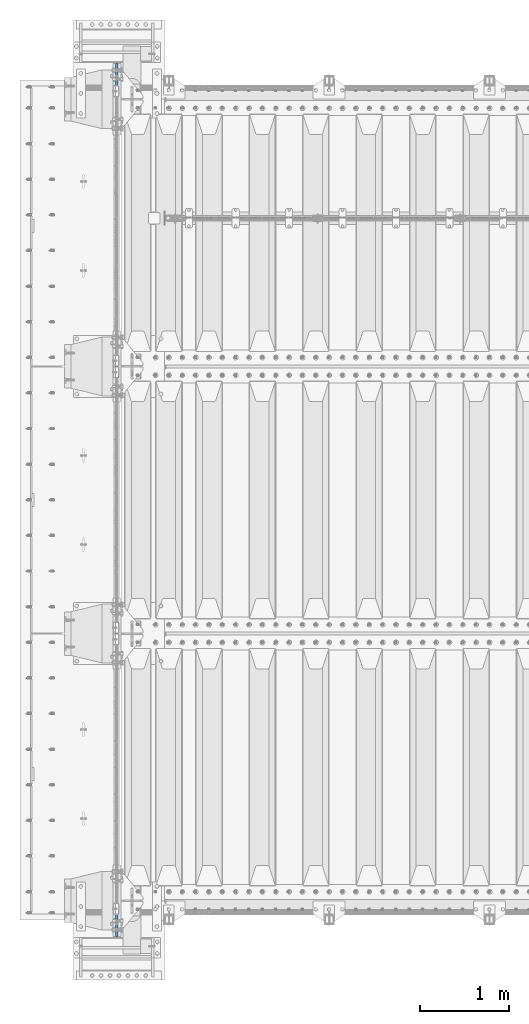
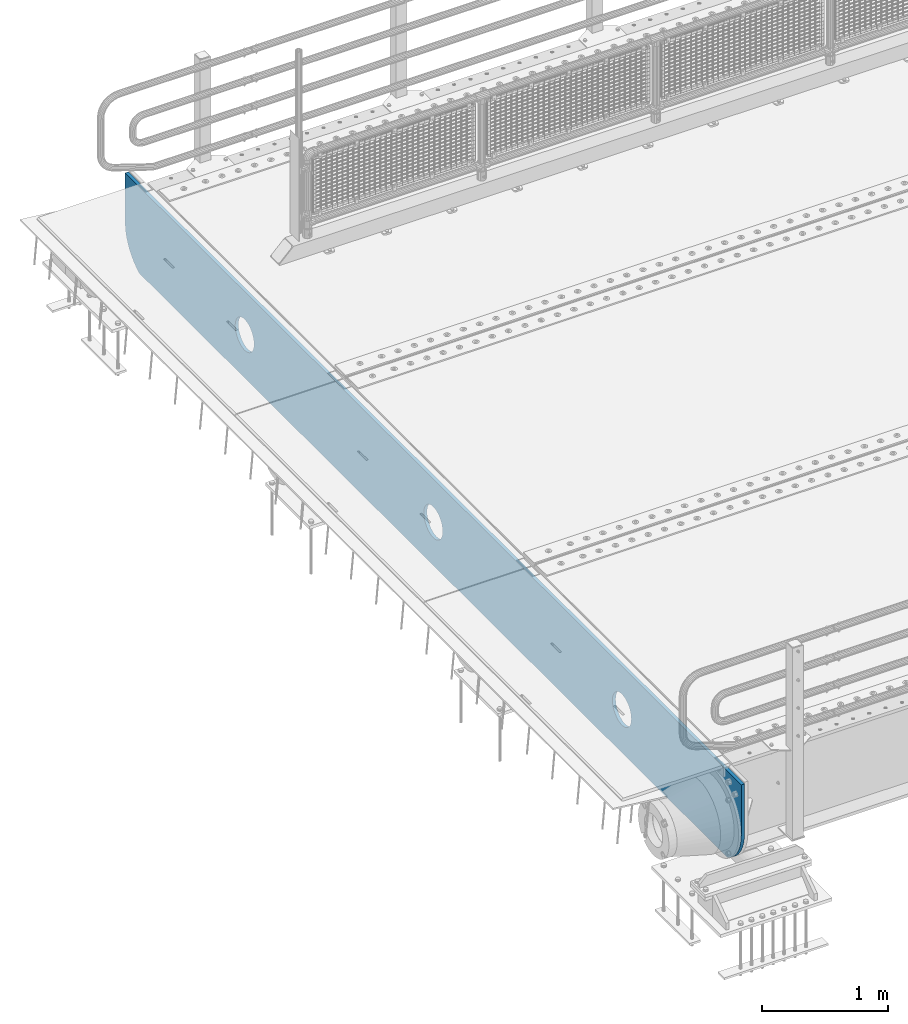
# One storey, part 191 of 247: 1 plate.
"""IFC2X3 building model written with IfcOpenShell, lengths in millimetres."""

from ifc_helpers import new_model, si_unit, frame, origin_with_axes, place, context, subcontext, project, spatial, faceted_brep, material, type_object, element, save


model = new_model("IFC2X3")

# Units and contexts
model_context = context("Model", 3, precision=1e-05, world=origin_with_axes())
body_context = subcontext(model_context, "Body", "Model", "MODEL_VIEW")
ifc_project = project(units=[si_unit("LENGTHUNIT", "METRE", prefix="MILLI"), si_unit("AREAUNIT", "SQUARE_METRE"), si_unit("VOLUMEUNIT", "CUBIC_METRE"), si_unit("MASSUNIT", "GRAM", prefix="KILO"), si_unit("TIMEUNIT", "SECOND"), si_unit("PLANEANGLEUNIT", "RADIAN"), si_unit("SOLIDANGLEUNIT", "STERADIAN"), si_unit("THERMODYNAMICTEMPERATUREUNIT", "DEGREE_CELSIUS"), si_unit("LUMINOUSINTENSITYUNIT", "LUMEN")], contexts=[model_context])

# Site, building, storey
site_placement = place(None, origin_with_axes())
site = spatial("IfcSite", under=ifc_project, at=site_placement, CompositionType="ELEMENT")
building_placement = place(site_placement, origin_with_axes())
building = spatial("IfcBuilding", under=site, at=building_placement, Name="Standard", CompositionType="ELEMENT")
storey_placement = place(building_placement, origin_with_axes())
storey = spatial("IfcBuildingStorey", under=building, at=storey_placement, Name="Undefined", CompositionType="ELEMENT", Elevation=0.0)

# Plate
ifc_material = material(Name="STEEL/S355N")
plate_type = type_object("IfcPlateType", PredefinedType="NOTDEFINED")
plate_placement = place(storey_placement, frame((-35.0, -400.0, -36.0000011039577), z_axis=(0.0, 1.0, 0.0), x_axis=(0.0, 0.0, -1.0)))
element("IfcPlate", 1, at=plate_placement, inside=storey, type_object=plate_type, material=ifc_material, context=body_context, shape_type="Brep", body=[
    faceted_brep([(449.263564616164, -15.0, 2047.11778936561), (449.263564616164, 15.0, 2047.11778936561), (477.402531117293, 15.0, 2038.58192701299), (477.402531117293, -15.0, 2038.58192701299), (503.335551132301, 15.0, 2024.72043882608), (503.335551132301, -15.0, 2024.72043882608), (526.066033245416, 15.0, 2006.0660140223), (526.066033245416, -15.0, 2006.0660140223), (544.720457776433, 15.0, 1983.33553168533), (544.720457776433, -15.0, 1983.33553168533), (558.581945652146, 15.0, 1957.40251150398), (558.581945652146, -15.0, 1957.40251150398), (567.117807667104, 15.0, 1929.26354490042), (567.117807667104, -15.0, 1929.26354490042), (570.000015431038, 15.0, 1899.99999658071), (570.000015431038, -15.0, 1899.99999658071), (567.117807315941, 15.0, 1870.73644829558), (567.117807315941, -15.0, 1870.73644829558), (558.581944963316, 15.0, 1842.59748179446), (558.581944963316, -15.0, 1842.59748179446), (544.720456776406, 15.0, 1816.66446177945), (544.720456776406, -15.0, 1816.66446177945), (526.066031972624, 15.0, 1793.93397966633), (526.066031972624, -15.0, 1793.93397966633), (503.335549635655, 15.0, 1775.27955513532), (503.335549635655, -15.0, 1775.27955513532), (477.40252945431, 15.0, 1761.4180672596), (477.40252945431, -15.0, 1761.4180672596), (449.26356285075, 15.0, 1752.88220524464), (449.26356285075, -15.0, 1752.88220524464), (420.000014531038, 15.0, 1749.99999748071), (420.000014531038, -15.0, 1749.99999748071), (390.736466245912, 15.0, 1752.88220559581), (390.736466245912, -15.0, 1752.88220559581), (362.597499744783, 15.0, 1761.41806794843), (362.597499744783, -15.0, 1761.41806794843), (336.664479729775, 15.0, 1775.27955613534), (336.664479729775, -15.0, 1775.27955613534), (313.933997616659, 15.0, 1793.93398093912), (313.933997616659, -15.0, 1793.93398093912), (295.279573085643, 15.0, 1816.66446327609), (295.279573085643, -15.0, 1816.66446327609), (281.41808520993, 15.0, 1842.59748345744), (281.41808520993, -15.0, 1842.59748345744), (272.882223194972, 15.0, 1870.736450061), (272.882223194972, -15.0, 1870.736450061), (270.000015431038, 15.0, 1899.99999838071), (270.000015431038, -15.0, 1899.99999838071), (272.882223546134, 15.0, 1929.26354666584), (272.882223546134, -15.0, 1929.26354666584), (281.41808589876, 15.0, 1957.40251316697), (281.41808589876, -15.0, 1957.40251316697), (295.279574085669, 15.0, 1983.33553318197), (295.279574085669, -15.0, 1983.33553318197), (313.933998889452, 15.0, 2006.06601529509), (313.933998889452, -15.0, 2006.06601529509), (336.66448122642, 15.0, 2024.72043982611), (336.66448122642, -15.0, 2024.72043982611), (362.597501407766, 15.0, 2038.58192770182), (362.597501407766, -15.0, 2038.58192770182), (390.736468011325, 15.0, 2047.11778971678), (390.736468011325, -15.0, 2047.11778971678), (420.000016331038, 15.0, 2049.99999748071), (420.000016331038, -15.0, 2049.99999748071), (-9.73792424474595e-07, 15.0, 9800.0), (-9.73792424474595e-07, -15.0, 9800.0), (479.000057686094, -15.0, 9799.99999712676), (479.000057656083, 15.0, 9800.0), (0.0, -15.0, 0.0), (0.0, 15.0, 0.0), (478.999999999949, 15.0, -7.38964445190504e-13), (478.999999999949, -15.0, -7.38964445190504e-13), (527.214672101572, 15.0, 2.91645036045298), (527.214672101572, -15.0, 2.91645036045298), (574.7262657145, 15.0, 11.6232730293116), (574.7262657145, -15.0, 11.6232730293116), (620.841954816524, 15.0, 25.993502925622), (620.841954816524, -15.0, 25.993502925622), (664.889268817045, 15.0, 45.8175897385568), (664.889268817045, -15.0, 45.8175897385568), (706.225898692028, 15.0, 70.806453642428), (706.225898692028, -15.0, 70.806453642428), (744.24906329591, 15.0, 100.595700731497), (744.24906329591, -15.0, 100.595700731497), (778.404299268057, 15.0, 134.750936703663), (778.404299268057, -15.0, 134.750936703663), (808.193546357102, 15.0, 172.774101307559), (808.193546357102, -15.0, 172.774101307559), (833.182410260948, 15.0, 214.110731182551), (833.182410260948, -15.0, 214.110731182551), (838.999998585997, -15.0, 227.03688218752), (838.999998585997, 15.0, 227.036882187521), (838.999940378846, 15.0, 9572.96326607018), (838.999940378846, -15.0, 9572.96326613684), (833.182425764908, 15.0, 9585.8892544658), (833.182425794908, -15.0, 9585.8892544658), (808.19356253396, 15.0, 9627.22588611663), (808.19356256396, -15.0, 9627.22588611663), (778.40431578726, 15.0, 9665.2490524771), (778.40431581726, -15.0, 9665.2490524771), (744.249079842992, 15.0, 9699.40429013405), (744.249079872992, -15.0, 9699.40429013405), (706.22591497628, 15.0, 9729.19353878739), (706.22591500628, -15.0, 9729.19353878739), (664.889284578492, 15.0, 9754.18240409113), (664.889284608492, -15.0, 9754.18240409113), (620.841969832053, 15.0, 9774.00649210145), (620.841969862053, -15.0, 9774.00649210145), (574.726279803044, 15.0, 9788.37672296115), (574.726279833044, -15.0, 9788.37672296115), (527.214685128208, 15.0, 9797.08354633522), (527.214685158208, -15.0, 9797.08354633522), (390.736498873119, -15.0, 8047.11778971678), (390.736498873119, 15.0, 8047.11778971678), (420.000047192832, 15.0, 8049.99999748071), (420.000047192832, -15.0, 8049.99999748071), (362.59753226956, -15.0, 8038.58192770182), (362.59753226956, 15.0, 8038.58192770182), (336.664512088214, -15.0, 8024.72043982611), (336.664512088214, 15.0, 8024.72043982611), (313.934029751246, -15.0, 8006.06601529509), (313.934029751246, 15.0, 8006.06601529509), (295.279604947463, -15.0, 7983.33553318197), (295.279604947463, 15.0, 7983.33553318197), (281.418116760554, -15.0, 7957.40251316697), (281.418116760554, 15.0, 7957.40251316697), (272.882254407928, -15.0, 7929.26354666584), (272.882254407928, 15.0, 7929.26354666584), (270.000046292832, -15.0, 7899.99999838071), (270.000046292832, 15.0, 7899.99999838071), (272.882254056766, -15.0, 7870.736450061), (272.882254056766, 15.0, 7870.736450061), (281.418116071723, -15.0, 7842.59748345744), (281.418116071723, 15.0, 7842.59748345744), (295.279603947437, -15.0, 7816.66446327609), (295.279603947437, 15.0, 7816.66446327609), (313.934028478453, -15.0, 7793.93398093912), (313.934028478453, 15.0, 7793.93398093912), (336.664510591569, -15.0, 7775.27955613534), (336.664510591569, 15.0, 7775.27955613534), (362.597530606576, -15.0, 7761.41806794843), (362.597530606576, 15.0, 7761.41806794843), (390.736497107706, -15.0, 7752.88220559581), (390.736497107706, 15.0, 7752.88220559581), (420.000045392832, -15.0, 7749.99999748071), (420.000045392832, 15.0, 7749.99999748071), (449.263593712544, -15.0, 7752.88220524465), (449.263593712544, 15.0, 7752.88220524465), (477.402560316104, -15.0, 7761.4180672596), (477.402560316104, 15.0, 7761.4180672596), (503.335580497449, -15.0, 7775.27955513532), (503.335580497449, 15.0, 7775.27955513532), (526.066062834418, -15.0, 7793.93397966633), (526.066062834418, 15.0, 7793.93397966633), (544.7204876382, -15.0, 7816.66446177945), (544.7204876382, 15.0, 7816.66446177945), (558.58197582511, -15.0, 7842.59748179446), (558.58197582511, 15.0, 7842.59748179446), (567.117838177735, -15.0, 7870.73644829558), (567.117838177735, 15.0, 7870.73644829558), (570.000046292832, -15.0, 7899.99999658071), (570.000046292832, 15.0, 7899.99999658071), (567.117838528897, -15.0, 7929.26354490042), (567.117838528897, 15.0, 7929.26354490042), (558.58197651394, -15.0, 7957.40251150398), (558.58197651394, 15.0, 7957.40251150398), (544.720488638227, -15.0, 7983.33553168533), (544.720488638227, 15.0, 7983.33553168533), (526.06606410721, -15.0, 8006.0660140223), (526.06606410721, 15.0, 8006.0660140223), (503.335581994095, -15.0, 8024.72043882608), (503.335581994095, 15.0, 8024.72043882608), (477.402561979087, -15.0, 8038.58192701299), (477.402561979087, 15.0, 8038.58192701299), (449.263595477958, -15.0, 8047.11778936561), (449.263595477958, 15.0, 8047.11778936561), (477.402546541581, -15.0, 5038.58192701299), (503.335566556588, -15.0, 5024.72043882608), (526.066048669704, -15.0, 5006.0660140223), (544.72047320072, -15.0, 4983.33553168533), (558.581961076434, -15.0, 4957.40251150398), (567.117823091391, -15.0, 4929.26354490042), (570.000030855326, -15.0, 4899.99999658071), (567.117822740229, -15.0, 4870.73644829558), (558.581960387603, -15.0, 4842.59748179446), (544.720472200694, -15.0, 4816.66446177945), (526.066047396912, -15.0, 4793.93397966633), (503.335565059943, -15.0, 4775.27955513532), (477.402544878597, -15.0, 4761.4180672596), (449.263578275038, -15.0, 4752.88220524464), (420.000029955325, -15.0, 4749.99999748071), (390.7364816702, -15.0, 4752.88220559581), (362.59751516907, -15.0, 4761.41806794843), (336.664495154063, -15.0, 4775.27955613534), (313.934013040947, -15.0, 4793.93398093912), (295.27958850993, -15.0, 4816.66446327609), (281.418100634217, -15.0, 4842.59748345744), (272.88223861926, -15.0, 4870.736450061), (270.000030855325, -15.0, 4899.99999838071), (272.882238970422, -15.0, 4929.26354666584), (281.418101323047, -15.0, 4957.40251316697), (295.279589509957, -15.0, 4983.33553318197), (313.934014313739, -15.0, 5006.06601529509), (336.664496650708, -15.0, 5024.72043982611), (362.597516832054, -15.0, 5038.58192770182), (390.736483435613, -15.0, 5047.11778971678), (420.000031755325, -15.0, 5049.99999748071), (449.263580040452, -15.0, 5047.11778936561), (362.597516832054, 15.0, 5038.58192770182), (390.736483435613, 15.0, 5047.11778971678), (336.664496650708, 15.0, 5024.72043982611), (313.934014313739, 15.0, 5006.06601529509), (295.279589509957, 15.0, 4983.33553318197), (281.418101323047, 15.0, 4957.40251316697), (272.882238970422, 15.0, 4929.26354666584), (270.000030855325, 15.0, 4899.99999838071), (272.88223861926, 15.0, 4870.736450061), (281.418100634217, 15.0, 4842.59748345744), (295.27958850993, 15.0, 4816.66446327609), (313.934013040947, 15.0, 4793.93398093912), (336.664495154063, 15.0, 4775.27955613534), (362.59751516907, 15.0, 4761.41806794843), (390.7364816702, 15.0, 4752.88220559581), (420.000029955325, 15.0, 4749.99999748071), (449.263578275038, 15.0, 4752.88220524464), (477.402544878597, 15.0, 4761.4180672596), (503.335565059943, 15.0, 4775.27955513532), (526.066047396912, 15.0, 4793.93397966633), (544.720472200694, 15.0, 4816.66446177945), (558.581960387603, 15.0, 4842.59748179446), (567.117822740229, 15.0, 4870.73644829558), (570.000030855326, 15.0, 4899.99999658071), (567.117823091391, 15.0, 4929.26354490042), (558.581961076434, 15.0, 4957.40251150398), (544.72047320072, 15.0, 4983.33553168533), (526.066048669704, 15.0, 5006.0660140223), (503.335566556588, 15.0, 5024.72043882608), (477.402546541581, 15.0, 5038.58192701299), (449.263580040452, 15.0, 5047.11778936561), (420.000031755325, 15.0, 5049.99999748071)], [[[0, 1, 2, 3]], [[3, 2, 4, 5]], [[5, 4, 6, 7]], [[7, 6, 8, 9]], [[9, 8, 10, 11]], [[11, 10, 12, 13]], [[13, 12, 14, 15]], [[15, 14, 16, 17]], [[17, 16, 18, 19]], [[19, 18, 20, 21]], [[21, 20, 22, 23]], [[23, 22, 24, 25]], [[25, 24, 26, 27]], [[27, 26, 28, 29]], [[29, 28, 30, 31]], [[31, 30, 32, 33]], [[33, 32, 34, 35]], [[35, 34, 36, 37]], [[37, 36, 38, 39]], [[39, 38, 40, 41]], [[41, 40, 42, 43]], [[43, 42, 44, 45]], [[45, 44, 46, 47]], [[47, 46, 48, 49]], [[49, 48, 50, 51]], [[51, 50, 52, 53]], [[53, 52, 54, 55]], [[55, 54, 56, 57]], [[57, 56, 58, 59]], [[59, 58, 60, 61]], [[61, 60, 62, 63]], [[63, 62, 1, 0]], [[64, 65, 66, 67]], [[68, 65, 64, 69]], [[68, 69, 70, 71]], [[71, 70, 72, 73]], [[73, 72, 74, 75]], [[75, 74, 76, 77]], [[77, 76, 78, 79]], [[79, 78, 80, 81]], [[81, 80, 82, 83]], [[83, 82, 84, 85]], [[85, 84, 86, 87]], [[87, 86, 88, 89]], [[90, 89, 88, 91]], [[90, 91, 92, 93]], [[93, 92, 94, 95]], [[95, 94, 96, 97]], [[97, 96, 98, 99]], [[99, 98, 100, 101]], [[101, 100, 102, 103]], [[103, 102, 104, 105]], [[105, 104, 106, 107]], [[107, 106, 108, 109]], [[109, 108, 110, 111]], [[66, 111, 110, 67]], [[112, 113, 114, 115]], [[116, 117, 113, 112]], [[118, 119, 117, 116]], [[120, 121, 119, 118]], [[122, 123, 121, 120]], [[124, 125, 123, 122]], [[126, 127, 125, 124]], [[128, 129, 127, 126]], [[130, 131, 129, 128]], [[132, 133, 131, 130]], [[134, 135, 133, 132]], [[136, 137, 135, 134]], [[138, 139, 137, 136]], [[140, 141, 139, 138]], [[142, 143, 141, 140]], [[144, 145, 143, 142]], [[146, 147, 145, 144]], [[148, 149, 147, 146]], [[150, 151, 149, 148]], [[152, 153, 151, 150]], [[154, 155, 153, 152]], [[156, 157, 155, 154]], [[158, 159, 157, 156]], [[160, 161, 159, 158]], [[162, 163, 161, 160]], [[164, 165, 163, 162]], [[166, 167, 165, 164]], [[168, 169, 167, 166]], [[170, 171, 169, 168]], [[172, 173, 171, 170]], [[174, 175, 173, 172]], [[115, 114, 175, 174]], [[65, 68, 71, 73, 75, 77, 79, 81, 83, 85, 87, 89, 90, 93, 95, 97, 99, 101, 103, 105, 107, 109, 111, 66], [3, 5, 7, 9, 11, 13, 15, 17, 19, 21, 23, 25, 27, 29, 31, 33, 35, 37, 39, 41, 43, 45, 47, 49, 51, 53, 55, 57, 59, 61, 63, 0], [176, 177, 178, 179, 180, 181, 182, 183, 184, 185, 186, 187, 188, 189, 190, 191, 192, 193, 194, 195, 196, 197, 198, 199, 200, 201, 202, 203, 204, 205, 206, 207], [172, 170, 168, 166, 164, 162, 160, 158, 156, 154, 152, 150, 148, 146, 144, 142, 140, 138, 136, 134, 132, 130, 128, 126, 124, 122, 120, 118, 116, 112, 115, 174]], [[204, 208, 209, 205]], [[203, 210, 208, 204]], [[202, 211, 210, 203]], [[201, 212, 211, 202]], [[200, 213, 212, 201]], [[199, 214, 213, 200]], [[198, 215, 214, 199]], [[197, 216, 215, 198]], [[196, 217, 216, 197]], [[195, 218, 217, 196]], [[194, 219, 218, 195]], [[193, 220, 219, 194]], [[192, 221, 220, 193]], [[191, 222, 221, 192]], [[190, 223, 222, 191]], [[189, 224, 223, 190]], [[188, 225, 224, 189]], [[187, 226, 225, 188]], [[186, 227, 226, 187]], [[185, 228, 227, 186]], [[184, 229, 228, 185]], [[183, 230, 229, 184]], [[182, 231, 230, 183]], [[181, 232, 231, 182]], [[180, 233, 232, 181]], [[179, 234, 233, 180]], [[178, 235, 234, 179]], [[177, 236, 235, 178]], [[176, 237, 236, 177]], [[207, 238, 237, 176]], [[206, 239, 238, 207]], [[205, 209, 239, 206]], [[108, 106, 104, 102, 100, 98, 96, 94, 92, 91, 88, 86, 84, 82, 80, 78, 76, 74, 72, 70, 69, 64, 67, 110], [58, 56, 54, 52, 50, 48, 46, 44, 42, 40, 38, 36, 34, 32, 30, 28, 26, 24, 22, 20, 18, 16, 14, 12, 10, 8, 6, 4, 2, 1, 62, 60], [208, 210, 211, 212, 213, 214, 215, 216, 217, 218, 219, 220, 221, 222, 223, 224, 225, 226, 227, 228, 229, 230, 231, 232, 233, 234, 235, 236, 237, 238, 239, 209], [117, 119, 121, 123, 125, 127, 129, 131, 133, 135, 137, 139, 141, 143, 145, 147, 149, 151, 153, 155, 157, 159, 161, 163, 165, 167, 169, 171, 173, 175, 114, 113]]]),
])

save(model, "model.ifc")
